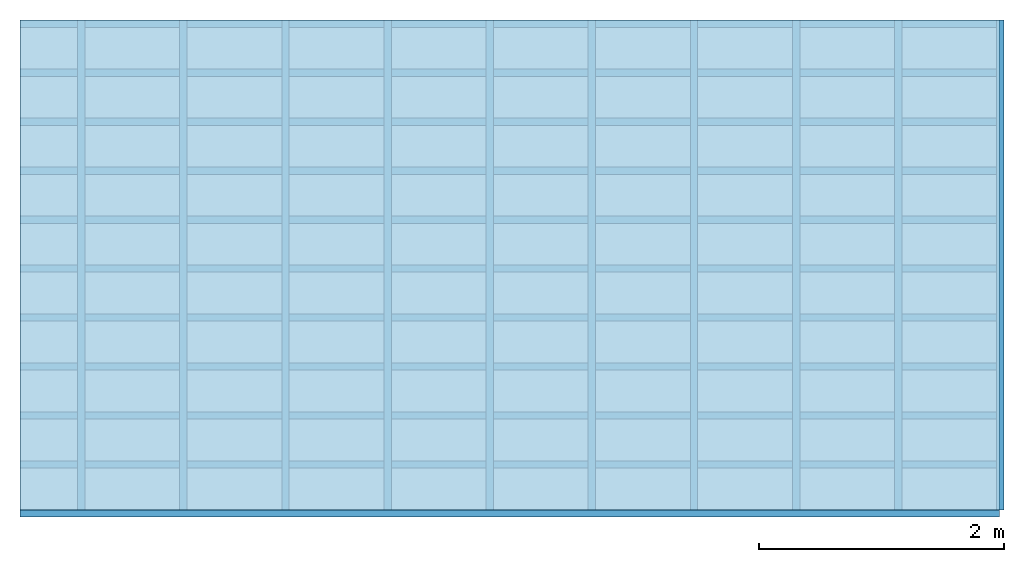
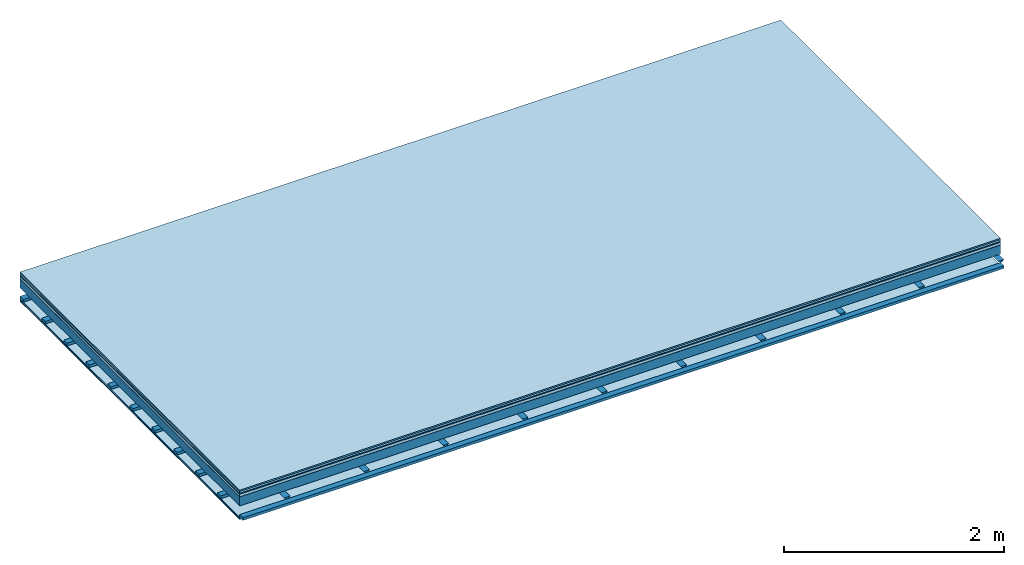
# One storey: 8 plates, 3 members, 1 element without a shape of its own.
"""IFC4 building model written with IfcOpenShell, lengths in metres."""

from ifc_helpers import new_model, si_unit, derived_unit, direction, frame, frame_2d, origin, origin_with_axes, place, context, project, spatial, polyline, rectangle, outline, extrude, material, layer, layer_set, type_object, element, aggregate, save


model = new_model("IFC4")

# Units and contexts
plan_context = context("Plan", 3, precision=1e-05, world=origin(), true_north=direction((0.0, 1.0)))
model_context = context("Model", 3, precision=1e-05, world=origin(), true_north=direction((0.0, 1.0)))
ifc_project = project(units=[si_unit("LENGTHUNIT", "METRE"), derived_unit("SOUNDPRESSUREUNIT", [(si_unit("PRESSUREUNIT", "PASCAL", prefix="MICRO"), 0)]), si_unit("ENERGYUNIT", "JOULE", prefix="MEGA"), si_unit("MASSUNIT", "GRAM", prefix="KILO"), derived_unit("THERMALTRANSMITTANCEUNIT", [(si_unit("POWERUNIT", "WATT"), 1), (si_unit("AREAUNIT", "SQUARE_METRE"), -1), (si_unit("THERMODYNAMICTEMPERATUREUNIT", "KELVIN"), -1)]), derived_unit("AREADENSITYUNIT", [(si_unit("MASSUNIT", "GRAM", prefix="KILO"), 1), (si_unit("AREAUNIT", "SQUARE_METRE"), -1)]), derived_unit("USERDEFINED", [(si_unit("ENERGYUNIT", "JOULE", prefix="MEGA"), 1), (si_unit("AREAUNIT", "SQUARE_METRE"), -1)])], contexts=[plan_context, model_context])

# Site, building, storey
site = spatial("IfcSite", under=ifc_project)
building_placement = place(None, origin())
building = spatial("IfcBuilding", under=site, at=building_placement)
storey_placement = place(building_placement, origin())
storey = spatial("IfcBuildingStorey", under=building, at=storey_placement)

# Slab, members, plates
ifc_material_1 = material(Category="11.013")
ifc_layer_1 = layer(ifc_material_1, 0.015, Name="Flooring")
ifc_material_2 = material(Category="03.007")
ifc_layer_2 = layer(ifc_material_2, 0.02, Name="On-material")
ifc_material_3 = material(Name="Wood fiber generic product", Category="10.009")
ifc_layer_3 = layer(ifc_material_3, 0.01, Name="Impact sound insulation")
ifc_material_4 = material(Name="with broken")
ifc_layer_4 = layer(ifc_material_4, 0.03, Name="on Supporting structure")
ifc_material_5 = material(Name="protection", Category="09.007")
ifc_layer_5 = layer(ifc_material_5, 0.0005, Name="Sub-floor")
ifc_material_6 = material(Name="no composite action")
ifc_layer_6 = layer(ifc_material_6, 0.0, Name="Bond")
ifc_layer_7 = layer(None, 0.1, Name="Supporting structure")
ifc_layer_8 = layer(ifc_material_6, 0.0, Name="Bond")
ifc_layer_9 = layer(None, 0.095, Name="Coupling")
ifc_layer_10 = layer(None, 0.03, Name="Battens / profiles")
ifc_material_7 = material(Name="Plasterboard type A", Category="03.008")
ifc_layer_11 = layer(ifc_material_7, 0.0125, Name="Ceiling covering 1st layer")
ifc_layer_12 = layer(ifc_material_7, 0.0125, Name="Ceiling covering layer 2")
ifc_material_8 = material(Category="04.001")
ifc_layer_13 = layer(ifc_material_8, 0.003, Name="Surface / treatment")
ifc_layer_set = layer_set([ifc_layer_1, ifc_layer_2, ifc_layer_3, ifc_layer_4, ifc_layer_5, ifc_layer_6, ifc_layer_7, ifc_layer_8, ifc_layer_9, ifc_layer_10, ifc_layer_11, ifc_layer_12, ifc_layer_13])
slab_type = type_object("IfcSlabType", Name="A2113", PredefinedType="NOTDEFINED", material=ifc_layer_set)
slab_placement = place(None, frame((0.0, 0.0, 0.0), z_axis=(0.0, 0.0, -1.0), x_axis=(1.0, 0.0, 0.0)))
slab = element("IfcSlab", 1, at=slab_placement, inside=storey, type_object=slab_type, material=ifc_layer_set, Name="Slab #1")
ifc_material_9 = material(Name="Solid timber panel")
member_1_placement = place(slab_placement, origin())
member_1 = element("IfcMember", 2, at=member_1_placement, material=ifc_material_9, Name="Supporting structure", context=plan_context, shape_type="SweptSolid", body=[
    extrude(rectangle(XDim=1.0, YDim=0.1, at=frame_2d((0.5, 0.05), x_axis=(1.0, 0.0))), frame((0.0, 4.0, 0.0755), z_axis=(0.0, -1.0, 0.0), x_axis=(1.0, 0.0, 0.0)), (0.0, 0.0, 1.0), 4.0),
    extrude(rectangle(XDim=1.0, YDim=0.1, at=frame_2d((0.5, 0.05), x_axis=(1.0, 0.0))), frame((1.0, 4.0, 0.0755), z_axis=(0.0, -1.0, 0.0), x_axis=(1.0, 0.0, 0.0)), (0.0, 0.0, 1.0), 4.0),
    extrude(rectangle(XDim=1.0, YDim=0.1, at=frame_2d((0.5, 0.05), x_axis=(1.0, 0.0))), frame((2.0, 4.0, 0.0755), z_axis=(0.0, -1.0, 0.0), x_axis=(1.0, 0.0, 0.0)), (0.0, 0.0, 1.0), 4.0),
    extrude(rectangle(XDim=1.0, YDim=0.1, at=frame_2d((0.5, 0.05), x_axis=(1.0, 0.0))), frame((3.0, 4.0, 0.0755), z_axis=(0.0, -1.0, 0.0), x_axis=(1.0, 0.0, 0.0)), (0.0, 0.0, 1.0), 4.0),
    extrude(rectangle(XDim=1.0, YDim=0.1, at=frame_2d((0.5, 0.05), x_axis=(1.0, 0.0))), frame((4.0, 4.0, 0.0755), z_axis=(0.0, -1.0, 0.0), x_axis=(1.0, 0.0, 0.0)), (0.0, 0.0, 1.0), 4.0),
    extrude(rectangle(XDim=1.0, YDim=0.1, at=frame_2d((0.5, 0.05), x_axis=(1.0, 0.0))), frame((5.0, 4.0, 0.0755), z_axis=(0.0, -1.0, 0.0), x_axis=(1.0, 0.0, 0.0)), (0.0, 0.0, 1.0), 4.0),
    extrude(rectangle(XDim=1.0, YDim=0.1, at=frame_2d((0.5, 0.05), x_axis=(1.0, 0.0))), frame((6.0, 4.0, 0.0755), z_axis=(0.0, -1.0, 0.0), x_axis=(1.0, 0.0, 0.0)), (0.0, 0.0, 1.0), 4.0),
    extrude(rectangle(XDim=1.0, YDim=0.1, at=frame_2d((0.5, 0.05), x_axis=(1.0, 0.0))), frame((7.0, 4.0, 0.0755), z_axis=(0.0, -1.0, 0.0), x_axis=(1.0, 0.0, 0.0)), (0.0, 0.0, 1.0), 4.0),
])
ifc_material_10 = material()
member_2_placement = place(slab_placement, origin())
member_2 = element("IfcMember", 3, at=member_2_placement, material=ifc_material_10, Name="Coupling", context=plan_context, shape_type="SweptSolid", body=[
    extrude(outline(polyline([(0.0, 0.0), (0.06, 0.0), (0.04, 0.02), (0.02, 0.02), (0.0, 0.0)])), frame((0.47, 4.0, 0.2505), z_axis=(0.0, -1.0, 0.0), x_axis=(1.0, 0.0, 0.0)), (0.0, 0.0, 1.0), 4.0),
    extrude(outline(polyline([(0.0, 0.0), (0.06, 0.0), (0.04, 0.02), (0.02, 0.02), (0.0, 0.0)])), frame((1.304, 4.0, 0.2505), z_axis=(0.0, -1.0, 0.0), x_axis=(1.0, 0.0, 0.0)), (0.0, 0.0, 1.0), 4.0),
    extrude(outline(polyline([(0.0, 0.0), (0.06, 0.0), (0.04, 0.02), (0.02, 0.02), (0.0, 0.0)])), frame((2.138, 4.0, 0.2505), z_axis=(0.0, -1.0, 0.0), x_axis=(1.0, 0.0, 0.0)), (0.0, 0.0, 1.0), 4.0),
    extrude(outline(polyline([(0.0, 0.0), (0.06, 0.0), (0.04, 0.02), (0.02, 0.02), (0.0, 0.0)])), frame((2.972, 4.0, 0.2505), z_axis=(0.0, -1.0, 0.0), x_axis=(1.0, 0.0, 0.0)), (0.0, 0.0, 1.0), 4.0),
    extrude(outline(polyline([(0.0, 0.0), (0.06, 0.0), (0.04, 0.02), (0.02, 0.02), (0.0, 0.0)])), frame((3.806, 4.0, 0.2505), z_axis=(0.0, -1.0, 0.0), x_axis=(1.0, 0.0, 0.0)), (0.0, 0.0, 1.0), 4.0),
    extrude(outline(polyline([(0.0, 0.0), (0.06, 0.0), (0.04, 0.02), (0.02, 0.02), (0.0, 0.0)])), frame((4.64, 4.0, 0.2505), z_axis=(0.0, -1.0, 0.0), x_axis=(1.0, 0.0, 0.0)), (0.0, 0.0, 1.0), 4.0),
    extrude(outline(polyline([(0.0, 0.0), (0.06, 0.0), (0.04, 0.02), (0.02, 0.02), (0.0, 0.0)])), frame((5.474, 4.0, 0.2505), z_axis=(0.0, -1.0, 0.0), x_axis=(1.0, 0.0, 0.0)), (0.0, 0.0, 1.0), 4.0),
    extrude(outline(polyline([(0.0, 0.0), (0.06, 0.0), (0.04, 0.02), (0.02, 0.02), (0.0, 0.0)])), frame((6.308, 4.0, 0.2505), z_axis=(0.0, -1.0, 0.0), x_axis=(1.0, 0.0, 0.0)), (0.0, 0.0, 1.0), 4.0),
    extrude(outline(polyline([(0.0, 0.0), (0.06, 0.0), (0.04, 0.02), (0.02, 0.02), (0.0, 0.0)])), frame((7.142, 4.0, 0.2505), z_axis=(0.0, -1.0, 0.0), x_axis=(1.0, 0.0, 0.0)), (0.0, 0.0, 1.0), 4.0),
    extrude(outline(polyline([(0.0, 0.0), (0.06, 0.0), (0.04, 0.02), (0.02, 0.02), (0.0, 0.0)])), frame((7.976, 4.0, 0.2505), z_axis=(0.0, -1.0, 0.0), x_axis=(1.0, 0.0, 0.0)), (0.0, 0.0, 1.0), 4.0),
])
member_3_placement = place(slab_placement, origin())
member_3 = element("IfcMember", 4, at=member_3_placement, material=ifc_material_10, Name="Battens / profiles", context=plan_context, shape_type="SweptSolid", body=[
    extrude(rectangle(XDim=0.06, YDim=0.03, at=frame_2d((0.03, 0.015), x_axis=(1.0, 0.0))), frame((0.0, 0.0, 0.2705), z_axis=(1.0, 0.0, 0.0), x_axis=(0.0, 1.0, 0.0)), (0.0, 0.0, 1.0), 8.0),
    extrude(rectangle(XDim=0.06, YDim=0.03, at=frame_2d((0.03, 0.015), x_axis=(1.0, 0.0))), frame((0.0, 0.4, 0.2705), z_axis=(1.0, 0.0, 0.0), x_axis=(0.0, 1.0, 0.0)), (0.0, 0.0, 1.0), 8.0),
    extrude(rectangle(XDim=0.06, YDim=0.03, at=frame_2d((0.03, 0.015), x_axis=(1.0, 0.0))), frame((0.0, 0.8, 0.2705), z_axis=(1.0, 0.0, 0.0), x_axis=(0.0, 1.0, 0.0)), (0.0, 0.0, 1.0), 8.0),
    extrude(rectangle(XDim=0.06, YDim=0.03, at=frame_2d((0.03, 0.015), x_axis=(1.0, 0.0))), frame((0.0, 1.2, 0.2705), z_axis=(1.0, 0.0, 0.0), x_axis=(0.0, 1.0, 0.0)), (0.0, 0.0, 1.0), 8.0),
    extrude(rectangle(XDim=0.06, YDim=0.03, at=frame_2d((0.03, 0.015), x_axis=(1.0, 0.0))), frame((0.0, 1.6, 0.2705), z_axis=(1.0, 0.0, 0.0), x_axis=(0.0, 1.0, 0.0)), (0.0, 0.0, 1.0), 8.0),
    extrude(rectangle(XDim=0.06, YDim=0.03, at=frame_2d((0.03, 0.015), x_axis=(1.0, 0.0))), frame((0.0, 2.0, 0.2705), z_axis=(1.0, 0.0, 0.0), x_axis=(0.0, 1.0, 0.0)), (0.0, 0.0, 1.0), 8.0),
    extrude(rectangle(XDim=0.06, YDim=0.03, at=frame_2d((0.03, 0.015), x_axis=(1.0, 0.0))), frame((0.0, 2.4, 0.2705), z_axis=(1.0, 0.0, 0.0), x_axis=(0.0, 1.0, 0.0)), (0.0, 0.0, 1.0), 8.0),
    extrude(rectangle(XDim=0.06, YDim=0.03, at=frame_2d((0.03, 0.015), x_axis=(1.0, 0.0))), frame((0.0, 2.8, 0.2705), z_axis=(1.0, 0.0, 0.0), x_axis=(0.0, 1.0, 0.0)), (0.0, 0.0, 1.0), 8.0),
    extrude(rectangle(XDim=0.06, YDim=0.03, at=frame_2d((0.03, 0.015), x_axis=(1.0, 0.0))), frame((0.0, 3.2, 0.2705), z_axis=(1.0, 0.0, 0.0), x_axis=(0.0, 1.0, 0.0)), (0.0, 0.0, 1.0), 8.0),
    extrude(rectangle(XDim=0.06, YDim=0.03, at=frame_2d((0.03, 0.015), x_axis=(1.0, 0.0))), frame((0.0, 3.6, 0.2705), z_axis=(1.0, 0.0, 0.0), x_axis=(0.0, 1.0, 0.0)), (0.0, 0.0, 1.0), 8.0),
    extrude(rectangle(XDim=0.06, YDim=0.03, at=frame_2d((0.03, 0.015), x_axis=(1.0, 0.0))), frame((0.0, 4.0, 0.2705), z_axis=(1.0, 0.0, 0.0), x_axis=(0.0, 1.0, 0.0)), (0.0, 0.0, 1.0), 8.0),
])
plate_1_placement = place(slab_placement, origin())
plate_1 = element("IfcPlate", 5, at=plate_1_placement, material=ifc_material_1, Name="Flooring", context=plan_context, shape_type="SweptSolid", body=[
    extrude(rectangle(XDim=8.0, YDim=4.0, at=frame_2d((4.0, 2.0), x_axis=(1.0, 0.0))), origin_with_axes(), (0.0, 0.0, 1.0), 0.015),
])
plate_2_placement = place(slab_placement, origin())
plate_2 = element("IfcPlate", 6, at=plate_2_placement, material=ifc_material_2, Name="On-material", context=plan_context, shape_type="SweptSolid", body=[
    extrude(rectangle(XDim=8.0, YDim=4.0, at=frame_2d((4.0, 2.0), x_axis=(1.0, 0.0))), frame((0.0, 0.0, 0.015), z_axis=(0.0, 0.0, 1.0), x_axis=(1.0, 0.0, 0.0)), (0.0, 0.0, 1.0), 0.02),
])
plate_3_placement = place(slab_placement, origin())
plate_3 = element("IfcPlate", 7, at=plate_3_placement, material=ifc_material_3, Name="Impact sound insulation", context=plan_context, shape_type="SweptSolid", body=[
    extrude(rectangle(XDim=8.0, YDim=4.0, at=frame_2d((4.0, 2.0), x_axis=(1.0, 0.0))), frame((0.0, 0.0, 0.035), z_axis=(0.0, 0.0, 1.0), x_axis=(1.0, 0.0, 0.0)), (0.0, 0.0, 1.0), 0.01),
])
plate_4_placement = place(slab_placement, origin())
plate_4 = element("IfcPlate", 8, at=plate_4_placement, material=ifc_material_4, Name="on Supporting structure", context=plan_context, shape_type="SweptSolid", body=[
    extrude(rectangle(XDim=8.0, YDim=4.0, at=frame_2d((4.0, 2.0), x_axis=(1.0, 0.0))), frame((0.0, 0.0, 0.045), z_axis=(0.0, 0.0, 1.0), x_axis=(1.0, 0.0, 0.0)), (0.0, 0.0, 1.0), 0.03),
])
plate_5_placement = place(slab_placement, origin())
plate_5 = element("IfcPlate", 9, at=plate_5_placement, material=ifc_material_5, Name="Sub-floor", context=plan_context, shape_type="SweptSolid", body=[
    extrude(rectangle(XDim=8.0, YDim=4.0, at=frame_2d((4.0, 2.0), x_axis=(1.0, 0.0))), frame((0.0, 0.0, 0.075), z_axis=(0.0, 0.0, 1.0), x_axis=(1.0, 0.0, 0.0)), (0.0, 0.0, 1.0), 0.0005),
])
plate_6_placement = place(slab_placement, origin())
plate_6 = element("IfcPlate", 10, at=plate_6_placement, material=ifc_material_7, Name="Ceiling covering 1st layer", context=plan_context, shape_type="SweptSolid", body=[
    extrude(rectangle(XDim=8.0, YDim=4.0, at=frame_2d((4.0, 2.0), x_axis=(1.0, 0.0))), frame((0.0, 0.0, 0.3005), z_axis=(0.0, 0.0, 1.0), x_axis=(1.0, 0.0, 0.0)), (0.0, 0.0, 1.0), 0.0125),
])
plate_7_placement = place(slab_placement, origin())
plate_7 = element("IfcPlate", 11, at=plate_7_placement, material=ifc_material_7, Name="Ceiling covering layer 2", context=plan_context, shape_type="SweptSolid", body=[
    extrude(rectangle(XDim=8.0, YDim=4.0, at=frame_2d((4.0, 2.0), x_axis=(1.0, 0.0))), frame((0.0, 0.0, 0.313), z_axis=(0.0, 0.0, 1.0), x_axis=(1.0, 0.0, 0.0)), (0.0, 0.0, 1.0), 0.0125),
])
plate_8_placement = place(slab_placement, origin())
plate_8 = element("IfcPlate", 12, at=plate_8_placement, material=ifc_material_8, Name="Surface / treatment", context=plan_context, shape_type="SweptSolid", body=[
    extrude(rectangle(XDim=8.0, YDim=4.0, at=frame_2d((4.0, 2.0), x_axis=(1.0, 0.0))), frame((0.0, 0.0, 0.3255), z_axis=(0.0, 0.0, 1.0), x_axis=(1.0, 0.0, 0.0)), (0.0, 0.0, 1.0), 0.003),
])
aggregate(slab, [plate_1, plate_2, plate_3, plate_4, plate_5, member_1, member_2, member_3, plate_6, plate_7, plate_8])

save(model, "model.ifc")
